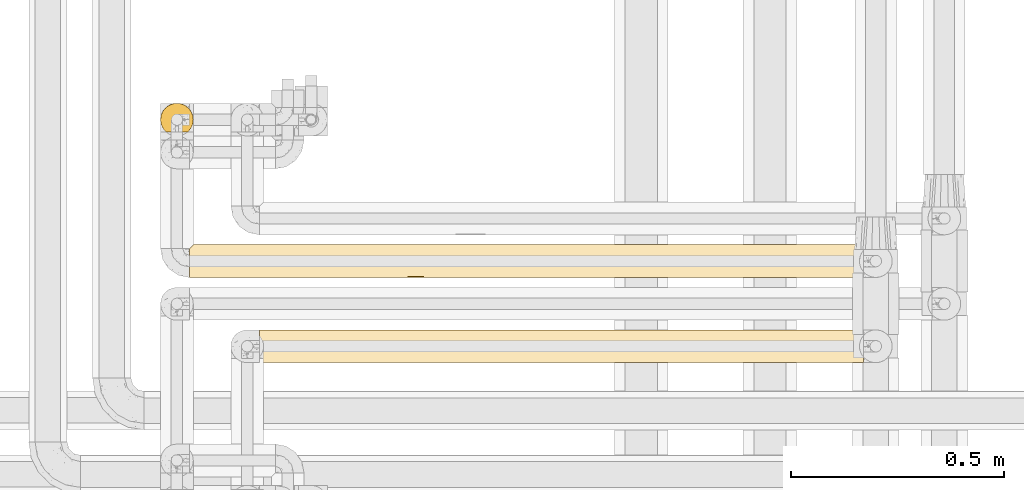
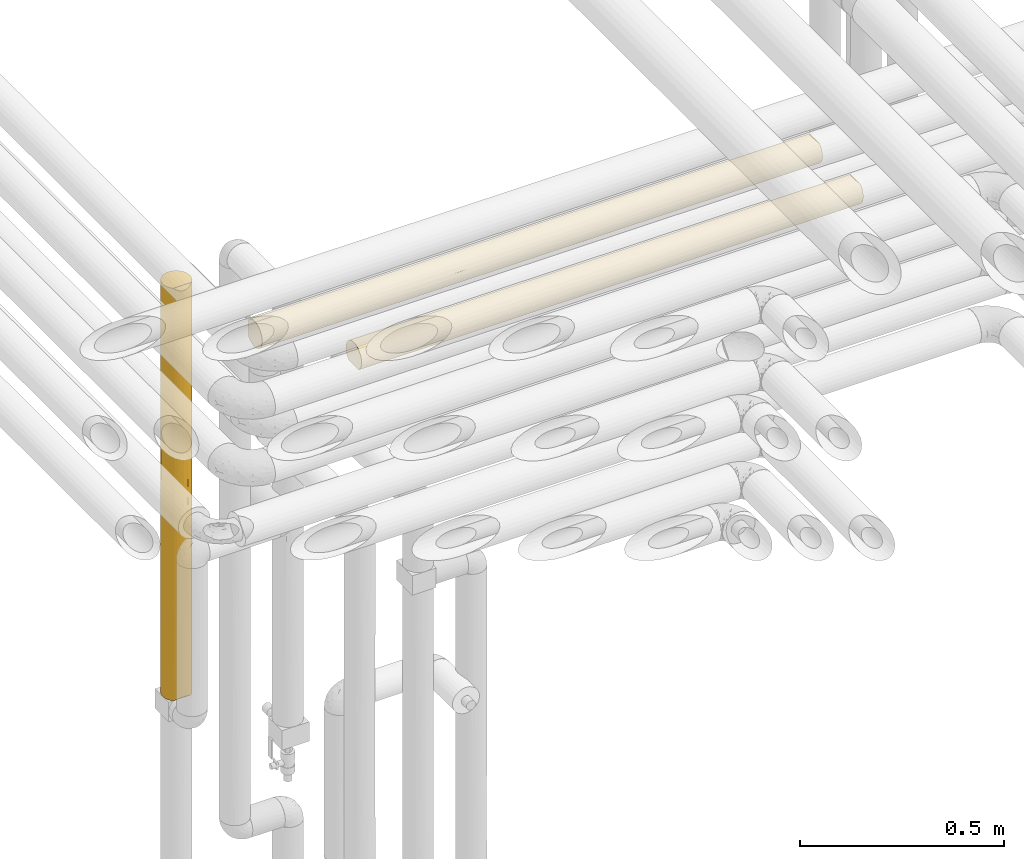
# One storey, part 39 of 824: 3 coverings.
"""IFC2X3 building model written with IfcOpenShell, lengths in millimetres."""

from ifc_helpers import new_model, entity, si_unit, converted_unit, derived_unit, direction, frame, origin, place, context, subcontext, project, spatial, faceted_brep, element, save


model = new_model("IFC2X3")

# Units and contexts
model_context = context("Model", 3, precision=0.01, world=origin(), true_north=direction((6.12303176911189e-17, 1.0)))
body_context = subcontext(model_context, "Body", "Model", "MODEL_VIEW")
ifc_project = project(units=[si_unit("LENGTHUNIT", "METRE", prefix="MILLI"), si_unit("AREAUNIT", "SQUARE_METRE"), si_unit("VOLUMEUNIT", "CUBIC_METRE"), converted_unit("PLANEANGLEUNIT", "DEGREE", entity("IfcRatioMeasure", 0.0174532925199433), si_unit("PLANEANGLEUNIT", "RADIAN"), dimensions=[0, 0, 0, 0, 0, 0, 0]), si_unit("MASSUNIT", "GRAM", prefix="KILO"), derived_unit("MASSDENSITYUNIT", [(si_unit("MASSUNIT", "GRAM", prefix="KILO"), 1), (si_unit("LENGTHUNIT", "METRE"), -3)]), derived_unit("MOMENTOFINERTIAUNIT", [(si_unit("LENGTHUNIT", "METRE"), 4)]), si_unit("TIMEUNIT", "SECOND"), si_unit("FREQUENCYUNIT", "HERTZ"), si_unit("THERMODYNAMICTEMPERATUREUNIT", "DEGREE_CELSIUS"), derived_unit("THERMALTRANSMITTANCEUNIT", [(si_unit("MASSUNIT", "GRAM", prefix="KILO"), 1), (si_unit("THERMODYNAMICTEMPERATUREUNIT", "KELVIN"), -1), (si_unit("TIMEUNIT", "SECOND"), -3)]), derived_unit("VOLUMETRICFLOWRATEUNIT", [(si_unit("LENGTHUNIT", "METRE"), 3), (si_unit("TIMEUNIT", "SECOND"), -1)]), derived_unit("MASSFLOWRATEUNIT", [(si_unit("MASSUNIT", "GRAM", prefix="KILO"), 1), (si_unit("TIMEUNIT", "SECOND"), -1)]), derived_unit("ROTATIONALFREQUENCYUNIT", [(si_unit("TIMEUNIT", "SECOND"), -1)]), si_unit("ELECTRICCURRENTUNIT", "AMPERE"), si_unit("ELECTRICVOLTAGEUNIT", "VOLT"), si_unit("POWERUNIT", "WATT"), si_unit("FORCEUNIT", "NEWTON", prefix="KILO"), si_unit("ILLUMINANCEUNIT", "LUX"), si_unit("LUMINOUSFLUXUNIT", "LUMEN"), si_unit("LUMINOUSINTENSITYUNIT", "CANDELA"), derived_unit("USERDEFINED", [(si_unit("MASSUNIT", "GRAM", prefix="KILO"), -1), (si_unit("LENGTHUNIT", "METRE"), -2), (si_unit("TIMEUNIT", "SECOND"), 3), (si_unit("LUMINOUSFLUXUNIT", "LUMEN"), 1)]), derived_unit("LINEARVELOCITYUNIT", [(si_unit("LENGTHUNIT", "METRE"), 1), (si_unit("TIMEUNIT", "SECOND"), -1)]), si_unit("PRESSUREUNIT", "PASCAL"), derived_unit("USERDEFINED", [(si_unit("LENGTHUNIT", "METRE"), -2), (si_unit("MASSUNIT", "GRAM", prefix="KILO"), 1), (si_unit("TIMEUNIT", "SECOND"), -2)]), derived_unit("LINEARFORCEUNIT", [(si_unit("MASSUNIT", "GRAM", prefix="KILO"), 1), (si_unit("LENGTHUNIT", "METRE"), 1), (si_unit("TIMEUNIT", "SECOND"), -2), (si_unit("LENGTHUNIT", "METRE"), -1)]), derived_unit("PLANARFORCEUNIT", [(si_unit("MASSUNIT", "GRAM", prefix="KILO"), 1), (si_unit("LENGTHUNIT", "METRE"), 1), (si_unit("TIMEUNIT", "SECOND"), -2), (si_unit("LENGTHUNIT", "METRE"), -2)])], contexts=[model_context])

# Site, building, storey
site_placement = place(None, origin())
site = spatial("IfcSite", under=ifc_project, at=site_placement, CompositionType="ELEMENT")
building_placement = place(site_placement, origin())
building = spatial("IfcBuilding", under=site, at=building_placement, CompositionType="ELEMENT")
storey_placement = place(building_placement, frame((0.0, 0.0, 28200.0)))
storey = spatial("IfcBuildingStorey", under=building, at=storey_placement, CompositionType="ELEMENT", Elevation=28200.0)

# Coverings
covering_1_placement = place(storey_placement, frame((34855.35, 15450.0, 2960.0)))
element("IfcCovering", 1, at=covering_1_placement, inside=storey, PredefinedType="INSULATION", context=body_context, shape_type="Brep", body=[
    faceted_brep([(1584.27, 59.2, 6.74), (1584.27, 67.15, 12.84), (1584.27, 73.25, 20.8), (1584.27, 77.09, 30.06), (1584.27, 78.4, 40.0), (1584.27, 77.51, 48.2), (1584.27, 74.9, 56.01), (1584.27, 70.68, 63.08), (1584.27, 65.05, 69.1), (1584.27, 14.94, 69.1), (1584.27, 9.31, 63.08), (1584.27, 5.09, 56.01), (1584.27, 2.48, 48.2), (1584.27, 1.6, 40.0), (1584.27, 2.9, 30.06), (1584.27, 6.74, 20.8), (1584.27, 12.84, 12.84), (1584.27, 20.8, 6.74), (1584.27, 30.06, 2.9), (1584.27, 40.0, 1.6), (1584.27, 49.93, 2.9), (1.6, 69.1, 14.94), (1.6, 63.08, 9.31), (1.6, 56.01, 5.09), (1.6, 48.2, 2.48), (1.6, 40.0, 1.6), (1.6, 30.06, 2.9), (1.6, 20.8, 6.74), (1.6, 12.84, 12.84), (1.6, 6.74, 20.8), (1.6, 2.9, 30.06), (1.6, 1.6, 40.0), (1.6, 2.9, 49.93), (1.6, 6.74, 59.2), (1.6, 12.84, 67.15), (1.6, 20.8, 73.25), (1.6, 30.06, 77.09), (1.6, 40.0, 78.4), (1.6, 48.2, 77.51), (1.6, 56.01, 74.9), (1.6, 63.08, 70.68), (1.6, 69.1, 65.05), (325.87, 16.62, 9.53), (1101.67, 12.02, 13.69), (1280.29, 16.62, 9.53), (1328.74, 9.53, 16.62), (260.79, 9.53, 16.62), (326.15, 2.41, 32.1), (223.22, 4.85, 24.51), (474.15, 4.52, 25.3), (1364.31, 33.26, 2.19), (1368.52, 25.3, 4.52), (574.48, 2.26, 32.88), (434.34, 1.6, 40.0), (780.34, 4.5, 25.35), (1274.34, 2.38, 32.28), (1367.89, 1.6, 40.0), (1225.68, 1.6, 40.0), (1137.67, 32.77, 2.28), (1225.68, 40.0, 1.6), (563.24, 33.12, 2.22), (819.98, 27.92, 3.54), (531.31, 25.3, 4.52), (246.65, 25.3, 4.52), (326.15, 32.71, 2.29), (567.7, 11.37, 14.4), (1398.66, 4.08, 26.39), (826.08, 2.33, 32.52), (804.78, 18.31, 8.3), (874.6, 9.53, 16.62), (1108.65, 25.3, 4.52), (1046.38, 2.24, 33.01), (564.73, 17.59, 8.81), (217.97, 40.0, 1.6), (217.97, 1.6, 40.0), (1045.77, 18.18, 8.39), (1151.52, 1.6, 40.0), (935.15, 1.6, 40.0), (867.09, 1.6, 40.0), (1066.7, 7.45, 19.62), (434.34, 40.0, 1.6), (650.71, 40.0, 1.6), (867.09, 40.0, 1.6), (1367.89, 40.0, 1.6), (1151.52, 40.0, 1.6), (650.71, 1.6, 40.0), (982.71, 4.52, 25.29), (1185.09, 4.52, 25.3), (718.77, 1.6, 40.0), (616.82, 49.74, 2.85), (287.23, 52.17, 3.58), (1009.3, 52.1, 3.55), (1259.71, 47.13, 2.26), (218.66, 59.66, 7.01), (712.29, 74.49, 23.13), (923.73, 76.93, 29.51), (906.39, 73.76, 21.71), (1375.48, 75.47, 25.3), (1364.99, 77.79, 33.21), (287.24, 66.24, 11.96), (544.14, 66.56, 12.26), (485.18, 59.66, 7.01), (830.9, 47.59, 2.35), (778.98, 54.79, 4.56), (227.27, 78.4, 40.0), (335.45, 77.5, 31.75), (10.29, 77.79, 33.21), (688.07, 76.94, 29.53), (384.99, 74.58, 23.31), (1137.87, 77.72, 32.83), (1230.33, 78.4, 40.0), (1367.59, 63.37, 9.53), (194.06, 71.13, 17.51), (8.5, 76.0, 26.63), (406.86, 70.58, 16.78), (1284.83, 70.46, 16.62), (1121.37, 75.47, 25.3), (1309.49, 54.69, 4.52), (443.64, 78.4, 40.0), (955.85, 68.71, 14.5), (795.9, 61.58, 8.23), (717.19, 70.91, 17.22), (1106.96, 63.37, 9.53), (5.57, 73.07, 20.48), (10.9, 78.4, 40.0), (876.39, 78.4, 40.0), (660.01, 78.4, 40.0), (335.45, 77.5, 48.24), (688.07, 76.94, 50.46), (1324.14, 72.98, 59.66), (1165.25, 68.03, 66.24), (1390.21, 68.15, 66.11), (734.57, 56.36, 74.73), (571.91, 49.12, 77.3), (862.09, 48.51, 77.44), (544.14, 66.56, 67.73), (406.86, 70.58, 63.21), (287.24, 66.24, 68.03), (194.06, 71.13, 62.48), (218.66, 59.66, 72.98), (10.29, 77.79, 46.78), (8.5, 76.0, 53.36), (1073.65, 47.06, 77.74), (1005.88, 56.77, 74.54), (1331.42, 62.51, 71.1), (1358.59, 40.0, 78.4), (1575.57, 46.78, 77.79), (1268.38, 50.2, 77.01), (287.23, 52.17, 76.41), (1150.23, 76.41, 52.17), (1383.53, 76.41, 52.17), (1111.82, 62.49, 71.12), (1220.6, 56.99, 74.43), (1580.3, 59.51, 73.07), (384.99, 74.58, 56.68), (988.17, 77.78, 46.82), (910.18, 75.77, 53.94), (1070.86, 72.93, 59.74), (5.57, 73.07, 59.51), (1577.37, 53.36, 76.0), (1574.97, 40.0, 78.4), (857.32, 64.49, 69.57), (485.18, 59.66, 72.98), (217.97, 40.0, 78.4), (355.53, 40.0, 78.4), (434.34, 40.0, 78.4), (709.48, 40.0, 78.4), (717.19, 70.91, 62.77), (730.61, 74.51, 56.82), (925.85, 40.0, 78.4), (1142.22, 40.0, 78.4), (301.04, 16.62, 70.46), (326.15, 2.26, 47.13), (447.99, 32.83, 77.72), (220.87, 33.21, 77.79), (210.38, 25.3, 75.47), (576.56, 3.55, 52.1), (1391.8, 17.51, 71.13), (1200.87, 23.31, 74.58), (1179.0, 16.78, 70.58), (464.49, 25.3, 75.47), (1577.37, 26.63, 76.0), (218.27, 9.53, 63.37), (1250.41, 31.75, 77.5), (1575.57, 33.21, 77.79), (1298.62, 11.96, 66.24), (1298.63, 3.58, 52.17), (897.8, 29.53, 76.94), (630.01, 14.5, 68.71), (789.96, 8.23, 61.58), (868.67, 17.22, 70.91), (806.88, 4.56, 54.79), (754.96, 2.35, 47.59), (969.05, 2.85, 49.74), (276.37, 4.52, 54.69), (1367.2, 7.01, 59.66), (1041.72, 12.26, 66.56), (1100.68, 7.01, 59.66), (478.91, 9.53, 63.37), (873.57, 23.13, 74.49), (662.13, 29.51, 76.93), (679.47, 21.71, 73.76), (1580.3, 20.48, 73.07)], [[[0, 1, 2, 3, 4, 5, 6, 7, 8, 9, 10, 11, 12, 13, 14, 15, 16, 17, 18, 19, 20]], [[21, 22, 23, 24, 25, 26, 27, 28, 29, 30, 31, 32, 33, 34, 35, 36, 37, 38, 39, 40, 41]], [[28, 27, 42]], [[43, 44, 45]], [[46, 28, 42]], [[47, 48, 49]], [[50, 18, 51]], [[52, 53, 47]], [[49, 54, 52]], [[55, 13, 56, 57]], [[58, 59, 50]], [[60, 61, 62]], [[27, 26, 63]], [[17, 16, 44]], [[63, 64, 62]], [[63, 42, 27]], [[46, 65, 49]], [[18, 17, 51]], [[44, 16, 45]], [[14, 55, 66]], [[52, 54, 67]], [[68, 69, 65]], [[44, 70, 51]], [[42, 63, 62]], [[57, 71, 55]], [[65, 42, 72]], [[26, 25, 73]], [[62, 64, 60]], [[74, 30, 47]], [[28, 46, 29]], [[16, 15, 45]], [[18, 50, 19]], [[43, 68, 75]], [[65, 46, 42]], [[47, 49, 52]], [[71, 57, 76, 77, 78]], [[48, 46, 49]], [[65, 72, 68]], [[65, 69, 54]], [[61, 68, 62]], [[43, 75, 44]], [[66, 45, 15]], [[43, 79, 69]], [[73, 64, 26]], [[64, 73, 80]], [[64, 80, 60]], [[26, 64, 63]], [[61, 81, 82]], [[82, 58, 61]], [[60, 81, 61]], [[61, 70, 75]], [[60, 80, 81]], [[44, 51, 17]], [[58, 50, 51]], [[58, 51, 70]], [[50, 59, 83, 19]], [[61, 58, 70]], [[58, 82, 84, 59]], [[47, 53, 74]], [[74, 31, 30]], [[48, 30, 29]], [[30, 48, 47]], [[46, 48, 29]], [[65, 54, 49]], [[67, 85, 52]], [[86, 69, 79]], [[71, 67, 86]], [[67, 71, 78]], [[85, 53, 52]], [[55, 71, 87]], [[79, 45, 87]], [[68, 43, 69]], [[61, 75, 68]], [[70, 44, 75]], [[45, 79, 43]], [[86, 79, 87]], [[71, 86, 87]], [[69, 86, 54]], [[66, 55, 87]], [[13, 55, 14]], [[45, 66, 87]], [[15, 14, 66]], [[67, 78, 88, 85]], [[86, 67, 54]], [[42, 62, 72]], [[62, 68, 72]], [[89, 80, 90]], [[91, 92, 84]], [[93, 23, 22]], [[94, 95, 96]], [[3, 97, 98]], [[97, 3, 2]], [[90, 73, 24]], [[22, 99, 93]], [[99, 100, 101]], [[91, 102, 103]], [[84, 82, 81, 102]], [[93, 101, 90]], [[92, 83, 59, 84]], [[104, 105, 106]], [[105, 107, 108]], [[109, 110, 98]], [[21, 99, 22]], [[1, 0, 111]], [[112, 113, 108]], [[23, 90, 24]], [[114, 112, 108]], [[103, 102, 89]], [[115, 116, 97]], [[115, 2, 1]], [[113, 106, 105]], [[20, 117, 0]], [[104, 118, 105]], [[119, 120, 121]], [[122, 119, 115]], [[111, 117, 122]], [[112, 21, 123]], [[114, 121, 100]], [[89, 90, 101]], [[24, 73, 25]], [[106, 124, 104]], [[125, 95, 107]], [[105, 108, 113]], [[125, 109, 95]], [[108, 107, 94]], [[111, 115, 1]], [[96, 119, 121]], [[101, 120, 103]], [[3, 98, 4]], [[102, 81, 89]], [[83, 92, 20]], [[122, 117, 91]], [[117, 111, 0]], [[80, 73, 90]], [[115, 111, 122]], [[20, 19, 83]], [[91, 117, 92]], [[20, 92, 117]], [[115, 97, 2]], [[109, 98, 97]], [[109, 97, 116]], [[4, 98, 110]], [[95, 109, 116]], [[125, 110, 109]], [[96, 95, 116]], [[107, 118, 126, 125]], [[115, 96, 116]], [[94, 96, 121]], [[115, 119, 96]], [[120, 119, 122]], [[91, 120, 122]], [[120, 101, 100]], [[114, 100, 99]], [[120, 100, 121]], [[99, 21, 112]], [[114, 108, 94]], [[112, 123, 113]], [[99, 112, 114]], [[94, 121, 114]], [[95, 94, 107]], [[101, 93, 99]], [[23, 93, 90]], [[118, 107, 105]], [[84, 102, 91]], [[101, 103, 89]], [[91, 103, 120]], [[81, 80, 89]], [[118, 127, 128]], [[129, 130, 131]], [[132, 133, 134]], [[135, 136, 137]], [[136, 138, 137]], [[40, 139, 137]], [[140, 141, 127]], [[142, 143, 134]], [[144, 131, 130]], [[5, 4, 110]], [[145, 146, 147]], [[38, 148, 39]], [[110, 149, 150]], [[130, 151, 144]], [[5, 150, 6]], [[152, 153, 144]], [[127, 141, 154]], [[7, 6, 129]], [[110, 150, 5]], [[155, 128, 156]], [[157, 130, 129]], [[139, 39, 148]], [[7, 131, 8]], [[158, 138, 141]], [[137, 41, 40]], [[152, 159, 153]], [[145, 160, 146]], [[134, 143, 132]], [[159, 147, 146]], [[125, 128, 155]], [[104, 124, 140]], [[153, 8, 144]], [[130, 157, 161]], [[162, 132, 161]], [[137, 139, 162]], [[148, 163, 164, 165]], [[118, 104, 127]], [[151, 143, 152]], [[135, 137, 162]], [[138, 158, 41]], [[148, 38, 163]], [[133, 165, 166]], [[150, 129, 6]], [[155, 110, 125]], [[157, 129, 149]], [[140, 127, 104]], [[127, 154, 128]], [[167, 168, 154]], [[157, 156, 168]], [[133, 166, 134]], [[162, 148, 133]], [[38, 37, 163]], [[165, 133, 148]], [[129, 150, 149]], [[134, 166, 169]], [[147, 142, 170]], [[161, 132, 143]], [[133, 132, 162]], [[161, 143, 151]], [[161, 167, 135]], [[156, 157, 149]], [[161, 157, 167]], [[155, 156, 149]], [[168, 156, 128]], [[110, 155, 149]], [[118, 128, 125, 126]], [[8, 131, 144]], [[129, 131, 7]], [[161, 135, 162]], [[136, 167, 154]], [[167, 136, 135]], [[154, 141, 138]], [[137, 138, 41]], [[154, 138, 136]], [[154, 168, 128]], [[157, 168, 167]], [[161, 151, 130]], [[152, 143, 147]], [[159, 152, 147]], [[144, 151, 152]], [[39, 139, 40]], [[162, 139, 148]], [[147, 170, 145]], [[143, 142, 147]], [[142, 169, 170]], [[169, 142, 134]], [[34, 171, 35]], [[53, 172, 74]], [[173, 164, 174]], [[36, 175, 174]], [[176, 172, 53]], [[177, 178, 179]], [[171, 180, 175]], [[181, 178, 177]], [[34, 33, 182]], [[145, 183, 184]], [[175, 36, 35]], [[9, 185, 10]], [[183, 145, 170]], [[186, 56, 12]], [[183, 187, 178]], [[188, 189, 190]], [[191, 192, 193]], [[32, 194, 33]], [[185, 195, 10]], [[185, 196, 197]], [[195, 11, 10]], [[11, 186, 12]], [[191, 176, 192]], [[193, 76, 186]], [[198, 188, 171]], [[181, 184, 183]], [[197, 186, 195]], [[199, 200, 201]], [[192, 53, 85, 88, 78, 77]], [[182, 194, 198]], [[177, 9, 202]], [[179, 190, 196]], [[193, 186, 197]], [[12, 56, 13]], [[184, 160, 145]], [[166, 200, 187]], [[183, 178, 181]], [[166, 173, 200]], [[178, 187, 199]], [[182, 171, 34]], [[201, 188, 190]], [[197, 189, 191]], [[36, 174, 37]], [[192, 77, 193]], [[74, 172, 32]], [[198, 194, 176]], [[194, 182, 33]], [[186, 76, 57, 56]], [[171, 182, 198]], [[32, 31, 74]], [[176, 194, 172]], [[32, 172, 194]], [[171, 175, 35]], [[173, 174, 175]], [[173, 175, 180]], [[174, 164, 163, 37]], [[200, 173, 180]], [[173, 166, 165, 164]], [[201, 200, 180]], [[187, 170, 169, 166]], [[171, 201, 180]], [[199, 201, 190]], [[171, 188, 201]], [[189, 188, 198]], [[176, 189, 198]], [[189, 197, 196]], [[179, 196, 185]], [[189, 196, 190]], [[185, 9, 177]], [[179, 178, 199]], [[177, 202, 181]], [[185, 177, 179]], [[199, 190, 179]], [[200, 199, 187]], [[197, 195, 185]], [[11, 195, 186]], [[170, 187, 183]], [[53, 192, 176]], [[197, 191, 193]], [[176, 191, 189]], [[77, 76, 193]], [[184, 181, 202, 9, 8, 153, 159, 146, 160]], [[41, 158, 141, 140, 124, 106, 113, 123, 21]]]),
])
covering_2_placement = place(storey_placement, frame((35020.39, 15250.0, 2960.0)))
element("IfcCovering", 2, at=covering_2_placement, inside=storey, PredefinedType="INSULATION", context=body_context, shape_type="Brep", body=[
    faceted_brep([(1.6, 2.48, 31.79), (1.6, 1.6, 40.0), (1.6, 2.9, 49.93), (1.6, 6.74, 59.2), (1.6, 12.84, 67.15), (1.6, 20.8, 73.25), (1.6, 30.06, 77.09), (1.6, 40.0, 78.4), (1.6, 49.93, 77.09), (1.6, 59.2, 73.25), (1.6, 67.15, 67.15), (1.6, 73.25, 59.2), (1.6, 77.09, 49.93), (1.6, 78.4, 40.0), (1.6, 77.51, 31.79), (1.6, 74.9, 23.98), (1.6, 70.68, 16.91), (1.6, 65.05, 10.9), (1.6, 14.94, 10.9), (1.6, 9.31, 16.91), (1.6, 5.09, 23.98), (1419.23, 2.9, 30.06), (1419.23, 6.74, 20.8), (1419.23, 12.84, 12.84), (1419.23, 20.8, 6.74), (1419.23, 30.06, 2.9), (1419.23, 40.0, 1.6), (1419.23, 49.93, 2.9), (1419.23, 59.2, 6.74), (1419.23, 67.15, 12.84), (1419.23, 73.25, 20.8), (1419.23, 77.09, 30.06), (1419.23, 78.4, 40.0), (1419.23, 77.51, 48.2), (1419.23, 74.9, 56.01), (1419.23, 70.68, 63.08), (1419.23, 65.05, 69.1), (1419.23, 14.94, 69.1), (1419.23, 9.31, 63.08), (1419.23, 5.09, 56.01), (1419.23, 2.48, 48.2), (1419.23, 1.6, 40.0), (1229.7, 75.47, 25.3), (1110.43, 77.61, 32.28), (335.45, 48.23, 2.49), (688.9, 50.52, 3.07), (443.64, 40.0, 1.6), (1131.67, 70.46, 16.62), (991.15, 75.47, 25.3), (823.92, 57.14, 5.63), (909.55, 48.15, 2.47), (218.54, 72.98, 20.33), (483.96, 72.98, 20.33), (286.74, 68.03, 13.75), (406.51, 63.21, 9.4), (542.75, 67.75, 13.46), (286.74, 76.41, 27.82), (798.34, 70.82, 17.1), (694.56, 74.52, 23.19), (1202.85, 40.0, 1.6), (227.27, 40.0, 1.6), (10.9, 40.0, 1.6), (10.29, 46.78, 2.2), (8.5, 53.36, 4.0), (383.15, 56.68, 5.41), (603.56, 57.1, 5.62), (193.87, 62.48, 8.86), (217.97, 78.4, 40.0), (1251.69, 54.69, 4.52), (1166.0, 63.37, 9.53), (5.57, 59.51, 6.92), (616.44, 77.13, 30.24), (876.39, 40.0, 1.6), (660.01, 40.0, 1.6), (939.95, 62.89, 9.17), (1140.96, 47.82, 2.4), (1030.22, 54.69, 4.52), (434.34, 78.4, 40.0), (878.56, 77.56, 32.01), (650.71, 78.4, 40.0), (770.09, 78.4, 40.0), (867.09, 78.4, 40.0), (986.47, 78.4, 40.0), (1202.85, 78.4, 40.0), (713.28, 62.77, 9.08), (553.73, 78.4, 40.0), (1131.67, 9.53, 16.62), (1166.0, 16.62, 9.53), (406.51, 16.78, 9.4), (713.28, 17.22, 9.08), (542.75, 12.24, 13.46), (1251.69, 25.3, 4.52), (1140.96, 32.17, 2.4), (193.87, 17.51, 8.86), (5.57, 20.48, 6.92), (383.15, 23.32, 5.41), (8.5, 26.63, 4.0), (1229.7, 4.52, 25.3), (335.45, 31.76, 2.49), (10.29, 33.21, 2.2), (286.74, 11.96, 13.75), (286.74, 3.58, 27.82), (217.97, 1.6, 40.0), (688.9, 29.47, 3.07), (991.15, 4.52, 25.3), (798.34, 9.17, 17.1), (1110.43, 2.38, 32.28), (940.93, 17.67, 8.75), (1030.22, 25.3, 4.52), (878.56, 2.43, 32.01), (218.54, 7.01, 20.33), (483.96, 7.01, 20.33), (616.44, 2.86, 30.24), (434.34, 1.6, 40.0), (597.6, 22.59, 5.77), (812.14, 23.29, 5.42), (867.09, 1.6, 40.0), (909.55, 31.84, 2.47), (757.89, 5.06, 24.05), (650.71, 1.6, 40.0), (1202.85, 1.6, 40.0), (986.48, 1.6, 40.0), (770.11, 1.6, 40.0), (553.74, 1.6, 40.0), (804.39, 2.86, 49.75), (1134.09, 3.58, 52.17), (1226.95, 17.51, 71.13), (1415.26, 20.48, 73.07), (1202.28, 7.01, 59.66), (823.23, 22.59, 74.22), (731.92, 29.47, 76.92), (608.69, 23.29, 74.57), (217.97, 40.0, 78.4), (254.82, 16.62, 70.46), (1134.08, 11.96, 66.24), (878.08, 12.24, 66.53), (936.86, 7.01, 59.66), (191.13, 4.52, 54.69), (310.4, 2.38, 47.71), (429.67, 4.52, 54.69), (542.26, 2.43, 47.98), (1014.31, 16.78, 70.59), (707.55, 17.22, 70.91), (1193.55, 40.0, 78.4), (1085.37, 31.76, 77.5), (1410.53, 33.21, 77.79), (1037.67, 23.32, 74.58), (169.13, 25.3, 75.47), (279.87, 32.17, 77.59), (289.15, 9.53, 63.37), (1412.33, 26.63, 76.0), (479.9, 17.67, 71.24), (390.6, 25.3, 75.47), (977.18, 40.0, 78.4), (622.48, 9.17, 62.89), (1409.93, 40.0, 78.4), (511.27, 31.84, 77.52), (760.81, 40.0, 78.4), (662.93, 5.06, 55.94), (544.43, 40.0, 78.4), (1085.37, 48.23, 77.5), (731.92, 50.52, 76.92), (1014.31, 63.21, 70.59), (1226.95, 62.48, 71.13), (1134.08, 68.03, 66.24), (1202.28, 72.98, 59.66), (289.15, 70.46, 63.37), (254.82, 63.37, 70.46), (1415.26, 59.51, 73.07), (1412.33, 53.36, 76.0), (1410.53, 46.78, 77.79), (936.86, 72.98, 59.66), (1134.09, 76.41, 52.17), (596.9, 57.14, 74.36), (511.27, 48.15, 77.52), (191.13, 75.47, 54.69), (480.87, 62.89, 70.82), (622.48, 70.82, 62.89), (1037.67, 56.68, 74.58), (169.13, 54.69, 75.47), (279.87, 47.82, 77.59), (390.6, 54.69, 75.47), (878.08, 67.75, 66.53), (726.26, 74.52, 56.8), (429.67, 75.47, 54.69), (310.4, 77.61, 47.71), (817.26, 57.1, 74.37), (804.39, 77.13, 49.75), (542.26, 77.56, 47.98), (707.55, 62.77, 70.91)], [[[0, 1, 2, 3, 4, 5, 6, 7, 8, 9, 10, 11, 12, 13, 14, 15, 16, 17, 18, 19, 20]], [[21, 22, 23, 24, 25, 26, 27, 28, 29, 30, 31, 32, 33, 34, 35, 36, 37, 38, 39, 40, 41]], [[31, 42, 43]], [[44, 45, 46]], [[42, 47, 48]], [[49, 50, 45]], [[51, 52, 53]], [[54, 53, 55]], [[56, 15, 14]], [[30, 42, 31]], [[57, 58, 48]], [[55, 53, 52]], [[27, 26, 59]], [[30, 29, 47]], [[53, 16, 51]], [[60, 61, 62]], [[56, 51, 15]], [[57, 48, 47]], [[44, 63, 64]], [[62, 63, 44]], [[45, 65, 49]], [[54, 66, 53]], [[14, 13, 67]], [[27, 68, 28]], [[47, 29, 69]], [[70, 66, 63]], [[17, 16, 53]], [[52, 56, 71]], [[50, 72, 73]], [[47, 74, 57]], [[46, 60, 44]], [[68, 75, 76]], [[66, 70, 17]], [[56, 67, 77]], [[71, 56, 77]], [[62, 44, 60]], [[44, 64, 45]], [[65, 45, 64]], [[50, 76, 75]], [[29, 28, 69]], [[57, 52, 58]], [[78, 79, 80, 81]], [[78, 81, 43]], [[43, 81, 82, 83]], [[83, 32, 31]], [[74, 47, 69]], [[14, 67, 56]], [[55, 57, 84]], [[68, 69, 28]], [[76, 49, 74]], [[47, 42, 30]], [[43, 42, 48]], [[43, 48, 78]], [[31, 43, 83]], [[58, 78, 48]], [[78, 71, 79]], [[57, 55, 52]], [[84, 65, 54]], [[84, 54, 55]], [[64, 63, 66]], [[53, 66, 17]], [[64, 66, 54]], [[15, 51, 16]], [[52, 51, 56]], [[75, 27, 59]], [[69, 68, 76]], [[27, 75, 68]], [[72, 75, 59]], [[75, 72, 50]], [[73, 46, 45]], [[50, 73, 45]], [[54, 65, 64]], [[49, 65, 84]], [[74, 49, 84]], [[49, 76, 50]], [[57, 74, 84]], [[76, 74, 69]], [[71, 77, 85, 79]], [[52, 71, 58]], [[58, 71, 78]], [[23, 86, 87]], [[88, 89, 90]], [[25, 91, 92]], [[25, 59, 26]], [[93, 18, 94]], [[88, 93, 95]], [[24, 91, 25]], [[96, 95, 93]], [[97, 86, 22]], [[60, 98, 99]], [[24, 23, 87]], [[18, 100, 19]], [[98, 60, 46]], [[101, 102, 0]], [[103, 95, 98]], [[104, 105, 86]], [[106, 104, 97]], [[107, 108, 87]], [[104, 106, 109]], [[100, 110, 19]], [[100, 90, 111]], [[110, 20, 19]], [[20, 101, 0]], [[21, 97, 22]], [[112, 113, 101]], [[22, 86, 23]], [[96, 99, 98]], [[111, 101, 110]], [[114, 103, 115]], [[116, 109, 106]], [[112, 101, 111]], [[0, 102, 1]], [[99, 61, 60]], [[117, 103, 73]], [[98, 95, 96]], [[108, 117, 92]], [[103, 117, 115]], [[104, 118, 105]], [[89, 115, 107]], [[111, 105, 118]], [[109, 119, 112]], [[21, 41, 120]], [[90, 105, 111]], [[59, 92, 72]], [[113, 102, 101]], [[105, 89, 107]], [[86, 105, 107]], [[91, 87, 108]], [[106, 21, 120]], [[86, 97, 104]], [[21, 106, 97]], [[106, 120, 121, 116]], [[109, 118, 104]], [[118, 109, 112]], [[88, 90, 100]], [[105, 90, 89]], [[100, 18, 93]], [[88, 95, 114]], [[93, 94, 96]], [[100, 93, 88]], [[111, 110, 100]], [[20, 110, 101]], [[87, 91, 24]], [[92, 91, 108]], [[115, 117, 108]], [[25, 92, 59]], [[103, 46, 73]], [[72, 92, 117]], [[46, 103, 98]], [[72, 117, 73]], [[114, 115, 89]], [[108, 107, 115]], [[107, 87, 86]], [[88, 114, 89]], [[103, 114, 95]], [[109, 116, 122, 119]], [[112, 119, 123, 113]], [[111, 118, 112]], [[124, 121, 125]], [[126, 37, 127]], [[128, 39, 38]], [[129, 130, 131]], [[6, 132, 7]], [[5, 4, 133]], [[125, 120, 40]], [[38, 134, 128]], [[134, 135, 136]], [[137, 3, 2]], [[138, 139, 137]], [[123, 140, 138]], [[128, 136, 125]], [[141, 142, 135]], [[143, 144, 145]], [[130, 146, 144]], [[6, 147, 148]], [[37, 134, 38]], [[137, 149, 3]], [[126, 150, 146]], [[39, 125, 40]], [[146, 141, 126]], [[151, 152, 133]], [[5, 147, 6]], [[149, 133, 4]], [[150, 145, 144]], [[139, 138, 140]], [[143, 153, 144]], [[139, 154, 149]], [[3, 149, 4]], [[124, 125, 136]], [[40, 120, 41]], [[145, 155, 143]], [[156, 130, 157]], [[144, 146, 150]], [[152, 156, 148]], [[130, 156, 131]], [[139, 158, 154]], [[142, 131, 151]], [[136, 154, 158]], [[140, 122, 124]], [[2, 1, 102]], [[135, 154, 136]], [[132, 148, 159]], [[121, 120, 125]], [[154, 142, 151]], [[149, 154, 151]], [[147, 133, 152]], [[138, 2, 102]], [[149, 137, 139]], [[2, 138, 137]], [[138, 102, 113, 123]], [[140, 158, 139]], [[158, 140, 124]], [[141, 135, 134]], [[154, 135, 142]], [[134, 37, 126]], [[141, 146, 129]], [[126, 127, 150]], [[134, 126, 141]], [[136, 128, 134]], [[39, 128, 125]], [[133, 147, 5]], [[148, 147, 152]], [[131, 156, 152]], [[6, 148, 132]], [[130, 153, 157]], [[159, 148, 156]], [[153, 130, 144]], [[159, 156, 157]], [[129, 131, 142]], [[152, 151, 131]], [[151, 133, 149]], [[141, 129, 142]], [[130, 129, 146]], [[140, 123, 119, 122]], [[124, 122, 116, 121]], [[136, 158, 124]], [[153, 160, 161]], [[162, 163, 164]], [[35, 165, 164]], [[166, 10, 167]], [[168, 163, 169]], [[164, 36, 35]], [[170, 169, 160]], [[153, 143, 160]], [[171, 164, 165]], [[172, 165, 34]], [[161, 173, 174]], [[11, 175, 12]], [[176, 177, 166]], [[160, 169, 178]], [[13, 12, 67]], [[179, 180, 181]], [[182, 164, 171]], [[11, 10, 166]], [[177, 183, 184]], [[12, 175, 185]], [[172, 34, 33]], [[8, 179, 9]], [[161, 186, 173]], [[162, 164, 182]], [[82, 172, 83]], [[171, 172, 187]], [[143, 155, 170]], [[184, 175, 166]], [[174, 159, 157]], [[177, 184, 166]], [[163, 168, 36]], [[172, 33, 83]], [[187, 172, 82]], [[170, 160, 143]], [[160, 178, 161]], [[186, 161, 178]], [[174, 181, 180]], [[10, 9, 167]], [[177, 171, 183]], [[188, 80, 79, 85]], [[188, 85, 185]], [[8, 7, 132]], [[185, 85, 77, 67]], [[33, 32, 83]], [[176, 166, 167]], [[182, 177, 189]], [[179, 167, 9]], [[181, 173, 176]], [[166, 175, 11]], [[185, 175, 184]], [[185, 184, 188]], [[12, 185, 67]], [[183, 188, 184]], [[188, 187, 80]], [[177, 182, 171]], [[189, 186, 162]], [[189, 162, 182]], [[178, 169, 163]], [[164, 163, 36]], [[178, 163, 162]], [[34, 165, 35]], [[171, 165, 172]], [[180, 8, 132]], [[167, 179, 181]], [[8, 180, 179]], [[159, 180, 132]], [[180, 159, 174]], [[157, 153, 161]], [[174, 157, 161]], [[162, 186, 178]], [[173, 186, 189]], [[176, 173, 189]], [[173, 181, 174]], [[177, 176, 189]], [[181, 176, 167]], [[187, 82, 81, 80]], [[171, 187, 183]], [[183, 187, 188]], [[17, 70, 63, 62, 61, 99, 96, 94, 18]], [[145, 150, 127, 37, 36, 168, 169, 170, 155]]]),
])
covering_3_placement = place(storey_placement, frame((34787.85, 15782.05, 1737.4)))
element("IfcCovering", 3, at=covering_3_placement, inside=storey, PredefinedType="INSULATION", context=body_context, shape_type="Brep", body=[
    faceted_brep([(70.82, 17.09, 1233.7), (74.96, 24.12, 1233.7), (77.53, 31.87, 1233.7), (78.4, 40.0, 1233.7), (77.09, 49.93, 1233.7), (73.25, 59.2, 1233.7), (67.15, 67.15, 1233.7), (59.2, 73.25, 1233.7), (49.93, 77.09, 1233.7), (40.0, 78.4, 1233.7), (30.06, 77.09, 1233.7), (20.8, 73.25, 1233.7), (12.84, 67.15, 1233.7), (6.74, 59.2, 1233.7), (2.9, 49.93, 1233.7), (1.6, 40.0, 1233.7), (2.47, 31.87, 1233.7), (5.03, 24.12, 1233.7), (9.17, 17.09, 1233.7), (14.71, 11.1, 1233.7), (65.28, 11.1, 1233.7), (77.09, 49.93, 1.6), (78.4, 40.0, 1.6), (77.52, 31.83, 1.6), (74.93, 24.05, 1.6), (70.75, 17.0, 1.6), (65.17, 11.0, 1.6), (14.82, 11.0, 1.6), (9.24, 17.0, 1.6), (5.06, 24.05, 1.6), (2.47, 31.83, 1.6), (1.6, 40.0, 1.6), (2.9, 49.93, 1.6), (6.74, 59.2, 1.6), (12.84, 67.15, 1.6), (20.8, 73.25, 1.6), (30.06, 77.09, 1.6), (40.0, 78.4, 1.6), (49.93, 77.09, 1.6), (59.2, 73.25, 1.6), (67.15, 67.15, 1.6), (73.25, 59.2, 1.6), (6.96, 20.41, 380.1), (2.98, 29.79, 300.66), (33.13, 2.21, 1224.81), (26.49, 4.05, 1226.65), (29.66, 3.01, 854.96), (1.6, 40.0, 1017.32), (3.54, 27.93, 959.65), (29.71, 3.0, 379.5), (40.0, 1.6, 314.3), (31.58, 2.53, 617.43), (6.92, 20.49, 1020.27), (6.91, 20.5, 776.67), (2.89, 30.11, 632.09), (17.23, 9.07, 932.57), (11.14, 14.65, 898.16), (11.15, 14.65, 658.7), (1.6, 40.0, 368.2), (1.6, 40.0, 217.97), (20.38, 6.98, 5.61), (26.56, 4.02, 8.57), (23.95, 5.11, 227.33), (7.37, 19.74, 578.55), (17.34, 8.99, 302.5), (11.15, 14.64, 236.7), (22.57, 5.78, 457.71), (33.17, 2.21, 10.38), (40.0, 1.6, 920.9), (24.03, 5.07, 687.57), (20.28, 7.04, 1229.64), (23.14, 5.49, 889.56), (17.16, 9.12, 617.33), (40.0, 1.6, 1007.82), (40.0, 1.6, 1224.2), (40.0, 1.6, 443.74), (40.0, 1.6, 617.6), (40.0, 1.6, 791.45), (1.6, 40.0, 800.95), (1.6, 40.0, 650.72), (1.6, 40.0, 584.58), (1.6, 40.0, 434.34), (12.88, 12.81, 447.73), (40.0, 1.6, 11.0), (40.0, 1.6, 227.37), (1.6, 40.0, 867.09), (46.86, 2.21, 1224.81), (78.4, 40.0, 368.2), (77.01, 29.79, 300.8), (62.94, 9.2, 617.95), (56.74, 5.44, 340.29), (65.84, 11.59, 318.76), (62.5, 8.88, 1022.28), (64.23, 10.21, 822.23), (68.21, 13.95, 960.82), (56.83, 5.48, 896.27), (59.71, 7.04, 1229.64), (53.5, 4.05, 1226.65), (59.61, 6.98, 5.61), (78.4, 40.0, 1017.32), (73.03, 20.41, 381.62), (46.82, 2.21, 10.38), (53.43, 4.02, 8.57), (48.19, 2.48, 335.55), (48.24, 2.49, 899.64), (73.08, 20.5, 1021.95), (76.45, 27.93, 960.83), (77.09, 30.08, 632.84), (73.08, 20.5, 779.63), (52.39, 3.65, 617.28), (74.53, 23.2, 580.01), (69.54, 15.47, 581.84), (78.4, 40.0, 800.95), (78.4, 40.0, 584.58), (70.46, 63.37, 260.79), (63.37, 70.46, 325.87), (77.74, 47.07, 909.14), (77.52, 48.15, 600.24), (75.47, 54.69, 874.58), (75.47, 54.69, 360.71), (77.67, 47.41, 240.44), (40.0, 78.4, 217.97), (74.83, 56.16, 600.23), (47.38, 77.68, 930.39), (54.69, 75.47, 246.65), (62.73, 70.94, 600.23), (54.69, 75.47, 531.31), (47.28, 77.7, 326.15), (63.37, 70.46, 874.58), (54.69, 75.47, 966.5), (70.46, 63.37, 966.5), (51.75, 76.55, 748.91), (70.46, 63.37, 617.65), (46.88, 77.77, 563.24), (40.0, 78.4, 368.2), (40.0, 78.4, 434.34), (40.0, 78.4, 650.71), (40.0, 78.4, 800.95), (40.0, 78.4, 867.08), (40.0, 78.4, 1017.32), (40.0, 78.4, 584.57), (16.62, 70.46, 260.79), (9.53, 63.37, 325.87), (32.92, 77.74, 909.14), (31.84, 77.52, 600.24), (25.3, 75.47, 874.58), (25.3, 75.47, 360.71), (32.58, 77.67, 240.44), (23.83, 74.83, 600.23), (2.31, 47.38, 930.39), (4.52, 54.69, 246.65), (9.05, 62.73, 600.23), (4.52, 54.69, 531.31), (2.29, 47.28, 326.15), (9.53, 63.37, 874.58), (4.52, 54.69, 966.5), (16.62, 70.46, 966.5), (3.44, 51.75, 748.91), (16.62, 70.46, 617.65), (2.22, 46.88, 563.24)], [[[0, 1, 2, 3, 4, 5, 6, 7, 8, 9, 10, 11, 12, 13, 14, 15, 16, 17, 18, 19, 20]], [[21, 22, 23, 24, 25, 26, 27, 28, 29, 30, 31, 32, 33, 34, 35, 36, 37, 38, 39, 40, 41]], [[42, 43, 29]], [[44, 45, 46]], [[16, 47, 48]], [[48, 17, 16]], [[49, 50, 51]], [[52, 48, 53]], [[53, 48, 54]], [[30, 43, 31]], [[55, 56, 57]], [[43, 58, 59, 31]], [[60, 61, 62]], [[63, 54, 42]], [[48, 52, 17]], [[27, 64, 65]], [[28, 65, 42]], [[62, 49, 66]], [[67, 62, 61]], [[29, 28, 42]], [[44, 46, 68]], [[56, 18, 52]], [[66, 51, 69]], [[67, 50, 49]], [[62, 67, 49]], [[45, 70, 71]], [[72, 55, 57]], [[44, 68, 73, 74]], [[19, 18, 56]], [[70, 19, 55]], [[51, 50, 75, 76, 77, 68]], [[71, 70, 55]], [[72, 69, 71]], [[60, 64, 27]], [[54, 78, 79, 80, 81, 58]], [[72, 57, 82]], [[54, 48, 78]], [[58, 43, 54]], [[56, 52, 53]], [[17, 52, 18]], [[56, 53, 57]], [[56, 55, 19]], [[53, 63, 57]], [[42, 65, 82]], [[54, 63, 53]], [[82, 63, 42]], [[51, 68, 46]], [[67, 83, 84, 50]], [[69, 51, 46]], [[71, 69, 46]], [[72, 64, 66]], [[45, 71, 46]], [[72, 71, 55]], [[29, 43, 30]], [[54, 43, 42]], [[49, 51, 66]], [[60, 62, 64]], [[72, 66, 69]], [[64, 62, 66]], [[27, 65, 28]], [[82, 65, 64]], [[72, 82, 64]], [[82, 57, 63]], [[47, 16, 15]], [[48, 47, 85, 78]], [[86, 74, 73]], [[87, 88, 22]], [[89, 90, 91]], [[92, 93, 94]], [[95, 96, 97]], [[98, 91, 90]], [[91, 98, 26]], [[99, 3, 2]], [[91, 25, 100]], [[101, 102, 103]], [[20, 94, 0]], [[102, 98, 90]], [[104, 73, 68, 77]], [[1, 105, 106]], [[73, 104, 86]], [[107, 106, 108]], [[103, 109, 75]], [[20, 96, 92]], [[88, 23, 22]], [[24, 23, 88]], [[100, 110, 111]], [[0, 105, 1]], [[1, 106, 2]], [[92, 96, 95]], [[106, 107, 112]], [[88, 107, 110]], [[97, 86, 104]], [[84, 83, 101]], [[2, 106, 99]], [[89, 95, 109]], [[103, 90, 109]], [[108, 105, 94]], [[94, 93, 111]], [[25, 24, 100]], [[103, 102, 90]], [[103, 75, 50, 84]], [[101, 103, 84]], [[95, 104, 109]], [[109, 77, 76, 75]], [[104, 95, 97]], [[109, 90, 89]], [[77, 109, 104]], [[110, 107, 108]], [[107, 87, 113, 112]], [[94, 105, 0]], [[106, 105, 108]], [[25, 91, 26]], [[111, 91, 100]], [[24, 88, 100]], [[94, 111, 108]], [[91, 111, 89]], [[93, 95, 89]], [[20, 92, 94]], [[95, 93, 92]], [[111, 93, 89]], [[106, 112, 99]], [[111, 110, 108]], [[88, 110, 100]], [[87, 107, 88]], [[114, 40, 115]], [[116, 117, 118]], [[4, 99, 116]], [[4, 118, 5]], [[21, 41, 119]], [[120, 22, 21]], [[38, 37, 121]], [[87, 120, 117]], [[118, 117, 122]], [[9, 8, 123]], [[39, 124, 115]], [[125, 115, 126]], [[124, 127, 126]], [[120, 21, 119]], [[112, 116, 99]], [[128, 129, 7]], [[130, 6, 5]], [[39, 38, 124]], [[39, 115, 40]], [[118, 130, 5]], [[128, 7, 6]], [[123, 129, 131]], [[128, 130, 132]], [[132, 114, 115]], [[125, 132, 115]], [[7, 129, 8]], [[40, 114, 41]], [[126, 127, 133]], [[114, 132, 119]], [[132, 130, 118]], [[131, 128, 125]], [[131, 126, 133]], [[128, 6, 130]], [[119, 41, 114]], [[121, 127, 38]], [[115, 124, 126]], [[127, 121, 134, 135]], [[127, 135, 133]], [[38, 127, 124]], [[123, 136, 137, 138, 139, 9]], [[133, 136, 131]], [[4, 3, 99]], [[128, 131, 129]], [[8, 129, 123]], [[136, 123, 131]], [[133, 135, 140, 136]], [[117, 116, 112]], [[4, 116, 118]], [[117, 112, 113, 87]], [[117, 119, 122]], [[117, 120, 119]], [[22, 120, 87]], [[131, 125, 126]], [[132, 125, 128]], [[119, 132, 122]], [[118, 122, 132]], [[141, 34, 142]], [[143, 144, 145]], [[10, 139, 143]], [[10, 145, 11]], [[36, 35, 146]], [[147, 37, 36]], [[32, 31, 59]], [[134, 147, 144]], [[145, 144, 148]], [[15, 14, 149]], [[33, 150, 142]], [[151, 142, 152]], [[150, 153, 152]], [[147, 36, 146]], [[143, 139, 138, 137]], [[154, 155, 13]], [[156, 12, 11]], [[33, 32, 150]], [[33, 142, 34]], [[145, 156, 11]], [[154, 13, 12]], [[149, 155, 157]], [[154, 156, 158]], [[158, 141, 142]], [[151, 158, 142]], [[13, 155, 14]], [[34, 141, 35]], [[152, 153, 159]], [[141, 158, 146]], [[157, 154, 151]], [[157, 152, 159]], [[158, 156, 145]], [[154, 12, 156]], [[146, 35, 141]], [[59, 153, 32]], [[142, 150, 152]], [[153, 59, 58, 81]], [[153, 81, 159]], [[32, 153, 150]], [[149, 79, 78, 85, 47, 15]], [[159, 79, 157]], [[10, 9, 139]], [[154, 157, 155]], [[14, 155, 149]], [[79, 149, 157]], [[159, 81, 80, 79]], [[144, 143, 137]], [[10, 143, 145]], [[144, 137, 136, 140, 135, 134]], [[144, 146, 148]], [[144, 147, 146]], [[147, 134, 121, 37]], [[157, 151, 152]], [[158, 151, 154]], [[146, 158, 148]], [[145, 148, 158]], [[70, 45, 44, 74, 86, 97, 96, 20, 19]], [[98, 102, 101, 83, 67, 61, 60, 27, 26]]]),
])

save(model, "model.ifc")
